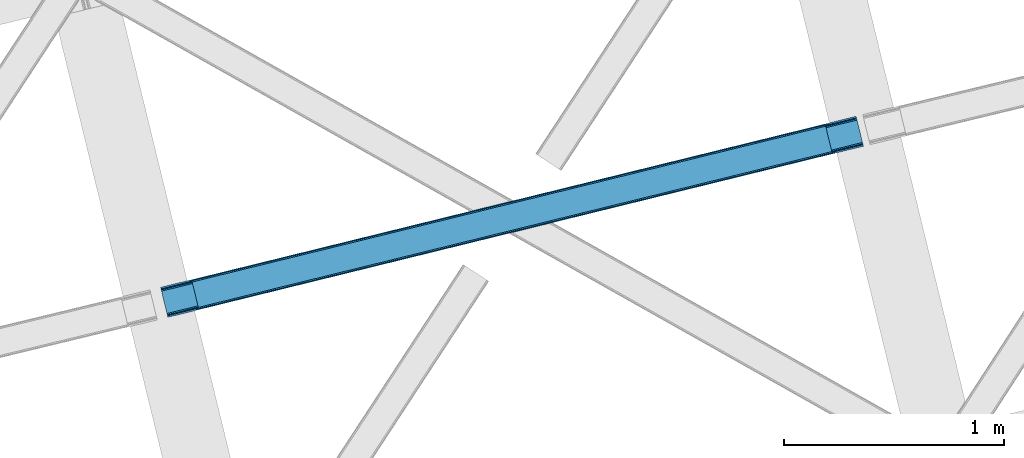
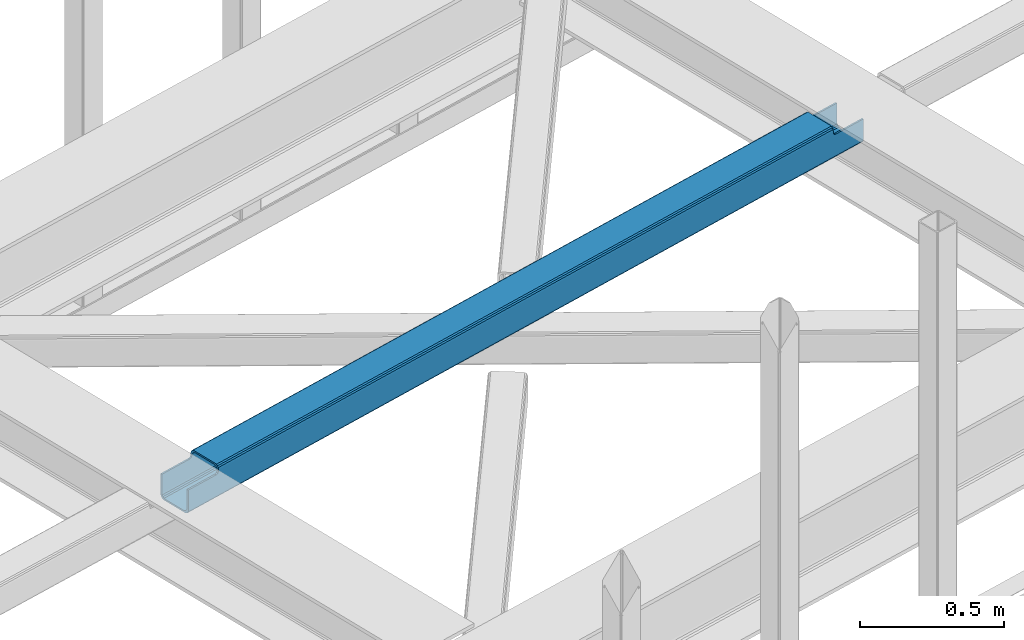
# One storey, part 34 of 66: 1 beam.
"""IFC4 building model written with IfcOpenShell, lengths in millimetres."""

from ifc_helpers import new_model, entity, si_unit, converted_unit, derived_unit, direction, frame, origin, place, context, subcontext, project, spatial, triangles, type_object, element, save


model = new_model("IFC4")

# Units and contexts
model_context = context("Model", 3, precision=0.01, world=origin(), true_north=direction((6.12303176911189e-17, 1.0)))
plan_context = context("Plan", 3, precision=0.01, world=origin(), true_north=direction((6.12303176911189e-17, 1.0)))
body_context = subcontext(model_context, "Body", "Model", "MODEL_VIEW")
ifc_project = project(units=[si_unit("LENGTHUNIT", "METRE", prefix="MILLI"), si_unit("AREAUNIT", "SQUARE_METRE"), si_unit("VOLUMEUNIT", "CUBIC_METRE"), converted_unit("PLANEANGLEUNIT", "DEGREE", entity("IfcRatioMeasure", 0.0174532925199433), si_unit("PLANEANGLEUNIT", "RADIAN"), dimensions=[0, 0, 0, 0, 0, 0, 0]), si_unit("MASSUNIT", "GRAM", prefix="KILO"), derived_unit("MASSDENSITYUNIT", [(si_unit("MASSUNIT", "GRAM", prefix="KILO"), 1), (si_unit("LENGTHUNIT", "METRE"), -3)]), derived_unit("MOMENTOFINERTIAUNIT", [(si_unit("LENGTHUNIT", "METRE"), 4)]), si_unit("TIMEUNIT", "SECOND"), si_unit("FREQUENCYUNIT", "HERTZ"), si_unit("THERMODYNAMICTEMPERATUREUNIT", "DEGREE_CELSIUS"), derived_unit("THERMALTRANSMITTANCEUNIT", [(si_unit("MASSUNIT", "GRAM", prefix="KILO"), 1), (si_unit("THERMODYNAMICTEMPERATUREUNIT", "KELVIN"), -1), (si_unit("TIMEUNIT", "SECOND"), -3)]), derived_unit("VOLUMETRICFLOWRATEUNIT", [(si_unit("LENGTHUNIT", "METRE"), 3), (si_unit("TIMEUNIT", "SECOND"), -1)]), derived_unit("MASSFLOWRATEUNIT", [(si_unit("MASSUNIT", "GRAM", prefix="KILO"), 1), (si_unit("TIMEUNIT", "SECOND"), -1)]), derived_unit("ROTATIONALFREQUENCYUNIT", [(si_unit("TIMEUNIT", "SECOND"), -1)]), si_unit("ELECTRICCURRENTUNIT", "AMPERE"), si_unit("ELECTRICVOLTAGEUNIT", "VOLT"), si_unit("POWERUNIT", "WATT"), si_unit("FORCEUNIT", "NEWTON", prefix="KILO"), si_unit("ILLUMINANCEUNIT", "LUX"), si_unit("LUMINOUSFLUXUNIT", "LUMEN"), si_unit("LUMINOUSINTENSITYUNIT", "CANDELA"), derived_unit("USERDEFINED", [(si_unit("MASSUNIT", "GRAM", prefix="KILO"), -1), (si_unit("LENGTHUNIT", "METRE"), -2), (si_unit("TIMEUNIT", "SECOND"), 3), (si_unit("LUMINOUSFLUXUNIT", "LUMEN"), 1)]), derived_unit("LINEARVELOCITYUNIT", [(si_unit("LENGTHUNIT", "METRE"), 1), (si_unit("TIMEUNIT", "SECOND"), -1)]), si_unit("PRESSUREUNIT", "PASCAL"), derived_unit("USERDEFINED", [(si_unit("LENGTHUNIT", "METRE"), -2), (si_unit("MASSUNIT", "GRAM", prefix="KILO"), 1), (si_unit("TIMEUNIT", "SECOND"), -2)]), derived_unit("LINEARFORCEUNIT", [(si_unit("MASSUNIT", "GRAM", prefix="KILO"), 1), (si_unit("LENGTHUNIT", "METRE"), 1), (si_unit("TIMEUNIT", "SECOND"), -2), (si_unit("LENGTHUNIT", "METRE"), -1)]), derived_unit("PLANARFORCEUNIT", [(si_unit("MASSUNIT", "GRAM", prefix="KILO"), 1), (si_unit("LENGTHUNIT", "METRE"), 1), (si_unit("TIMEUNIT", "SECOND"), -2), (si_unit("LENGTHUNIT", "METRE"), -2)])], contexts=[model_context, plan_context])

# Site, building, storey
site_placement = place(None, origin())
site = spatial("IfcSite", under=ifc_project, at=site_placement, CompositionType="ELEMENT")
building_placement = place(site_placement, origin())
building = spatial("IfcBuilding", under=site, at=building_placement, CompositionType="ELEMENT")
storey_placement = place(building_placement, frame((0.0, 0.0, 19800.0)))
storey = spatial("IfcBuildingStorey", under=building, at=storey_placement, Name="06", CompositionType="ELEMENT", Elevation=19800.0)

# Beam
beam_type = type_object("IfcBeamType", PredefinedType="BEAM")
beam_placement = place(storey_placement, frame((-36151.91, 10320.64, 3967.03)))
element("IfcBeam", 1, at=beam_placement, inside=storey, type_object=beam_type, ObjectType="Steel Beam", PredefinedType="BEAM", context=body_context, shape_type="Tessellation", body=[
    triangles([(3160.10943603516, 895.15698852539, 0.0), (3184.97536010742, 793.143447875977, 0.0), (4.14393310546438, 119.014828491212, 0.965057373046875), (29.012182617189, 17.0012878417965, 0.965057373046875), (3155.96550292968, 912.159439086914, 17.4989318847656), (3156.27943725586, 910.86533203125, 10.8016662597656), (0.0, 136.017279052734, 18.4639892578125), (0.316259765626455, 134.723171997071, 11.7667236328125), (3157.17938232422, 907.179510498047, 5.12526855468604), (1.21387939452688, 131.037350463868, 6.09032592773292), (3158.52348632812, 901.663568115235, 1.33247680664135), (2.5579833984375, 125.521408081055, 2.29753417968823), (3186.56130981445, 786.636868286134, 1.33247680664135), (30.5981323242158, 10.4947082519539, 2.29753417968823), (3187.90773925781, 781.12092590332, 5.12526855468604), (31.9422363281265, 4.97876586914026, 6.09032592773292), (3188.80535888672, 777.436267089844, 10.8016662597656), (32.8398559570269, 1.29410705566443, 11.7667236328125), (3189.12161865235, 776.140997314453, 17.4989318847656), (33.1561157226533, 0.0, 18.4639892578125), (2.87191772460938, 124.236602783203, 13.0898986816392), (4.21602172851271, 118.720660400391, 9.29710693359448), (5.80197143554688, 112.214080810547, 7.96463012695313), (1.97429809570167, 127.922424316406, 18.7662963867188), (0.0, 136.017279052734, 105.472631835935), (1.65803833007521, 129.216531372071, 25.4635620117188), (1.65803833007521, 129.216531372071, 105.472631835935), (28.9400939941406, 17.2966186523445, 9.29710693359448), (30.284197998044, 11.7806762695309, 13.0898986816392), (27.3541442871065, 23.8020355224617, 7.96463012695313), (31.1818176269517, 8.09485473632776, 18.7662963867188), (31.4980773925781, 6.80074768066515, 25.4635620117188), (33.1561157226533, 0.0, 105.472631835935), (31.4980773925781, 6.80074768066515, 105.472631835935), (3183.3196472168, 799.944195556642, 6.99957275390625), (3161.76747436523, 888.356240844727, 6.99957275390625), (3160.1815246582, 894.862820434571, 8.3320495605476), (3158.83742065429, 900.378762817383, 12.1248413085923), (3157.93747558594, 904.064584350586, 17.8035644531228), (3157.62354125977, 905.358691406251, 24.4985046386719), (3187.46358032226, 782.942907714843, 24.4985046386719), (3187.14732055664, 784.237014770508, 17.8035644531228), (3186.24970092774, 787.922836303711, 12.1248413085923), (3184.90559692383, 793.438778686525, 8.3320495605476), (131.782653808594, 161.216903686523, 105.472631835935), (130.124615478511, 168.018814086914, 105.472631835935), (163.280731201172, 32.0003723144528, 105.472631835935), (161.622692871089, 38.8011199951179, 105.472631835935), (3155.96550292968, 912.159439086914, 104.491296386717), (3157.62354125977, 905.358691406251, 104.491296386717), (3189.12161865235, 776.140997314453, 104.491296386717), (3187.46358032226, 782.942907714843, 104.491296386717), (3025.84321289062, 880.157904052734, 104.491296386717), (3027.5012512207, 873.357156372071, 104.491296386717), (3057.3412902832, 750.941372680665, 104.491296386717), (3058.99932861328, 744.140625, 104.491296386717), (3022.06437377929, 879.228890991211, 106.102825927734), (3023.72241210938, 872.428143310548, 106.102825927734), (3018.29018554687, 878.301040649414, 107.71435546875), (3019.94822387695, 871.500292968751, 107.71435546875), (3016.72516479492, 877.916180419923, 111.602490234374), (3018.383203125, 871.115432739258, 111.602490234374), (3015.16246948242, 877.53132019043, 115.492950439453), (3016.8205078125, 870.730572509767, 115.541784667967), (3049.88128051758, 741.898901367187, 111.602490234374), (3048.2232421875, 748.699649047852, 111.602490234374), (3046.660546875, 748.314788818359, 115.492950439453), (3048.31858520507, 741.514041137696, 115.492950439453), (3051.44630126953, 742.28376159668, 107.71435546875), (3049.78826293945, 749.084509277343, 107.71435546875), (3055.22048950195, 743.211611938477, 106.102825927734), (3053.56245117187, 750.012359619141, 106.102825927734), (140.910003662109, 163.462115478516, 112.581500244141), (142.463397216794, 163.844650268555, 116.471960449217), (139.335681152341, 163.074929809571, 108.693365478513), (135.556842041013, 162.145916748048, 107.081835937501), (170.750042724605, 41.046331787109, 112.581500244141), (169.175720214844, 40.6591461181652, 108.693365478513), (165.39920654297, 39.7301330566406, 107.081835937501), (172.303436279297, 41.4288665771492, 116.471960449217), (139.240338134761, 170.260537719727, 112.583825683592), (140.805358886719, 170.64539794922, 116.471960449217), (137.677642822266, 169.875677490234, 108.693365478513), (133.901129150392, 168.946664428711, 107.081835937501), (170.833758544919, 33.8583984375, 108.693365478513), (172.396453857422, 34.2420959472656, 112.583825683592), (173.961474609372, 34.6269561767585, 116.471960449217), (167.054919433591, 32.9293853759773, 107.081835937501), (3015.16246948242, 877.53132019043, 122.541357421873), (140.805358886719, 170.64539794922, 123.420373535155), (3048.31858520507, 741.514041137696, 122.541357421873), (173.961474609372, 34.6269561767585, 123.420373535155), (3017.13444213867, 869.436465454102, 122.239050292967), (142.77965698242, 162.55054321289, 123.118066406249), (3018.03438720703, 865.750643920899, 127.917773437501), (143.677276611328, 158.864721679687, 128.794464111328), (3019.37849121093, 860.234701538086, 131.710565185545), (145.021380615231, 153.348779296875, 132.589581298827), (3020.96444091797, 853.728121948243, 133.043041992187), (146.607330322266, 146.842199707031, 133.922058105469), (3046.34428710937, 749.608895874024, 122.239050292967), (171.98717651367, 42.7229736328136, 123.118066406249), (3042.51661376953, 765.317239379883, 133.043041992187), (3044.10256347656, 758.810659790039, 131.710565185545), (168.159503173825, 58.4301544189457, 133.922058105469), (169.745452880859, 51.9247375488285, 132.589581298827), (3045.44666748046, 753.294717407227, 127.917773437501), (171.089556884763, 46.4087951660167, 128.796789550779), (3015.47640380859, 876.237213134766, 129.238623046873), (3016.37634887695, 872.551391601563, 134.917346191407), (3017.72045288086, 867.035449218751, 138.710137939452), (3019.30640258789, 860.530032348634, 140.042614746093), (3045.75827636719, 752.009912109375, 138.710137939452), (3044.17232666015, 758.51649169922, 140.042614746093), (3047.10470581055, 746.493969726564, 134.917346191407), (3048.00232543945, 742.80814819336, 129.238623046873), (141.121618652345, 169.351290893555, 130.117639160155), (142.019238281246, 165.665469360352, 135.796362304685), (143.363342285156, 160.149526977539, 139.589154052734), (144.949291992183, 153.642947387696, 140.921630859375), (171.403491210935, 45.1228271484379, 139.589154052734), (169.817541503908, 51.6294067382823, 140.921630859375), (172.747595214845, 39.6068847656261, 135.796362304685), (173.645214843746, 35.9222259521484, 130.117639160155)], [[1, 2, 3], [4, 3, 2], [5, 6, 7], [8, 7, 6], [6, 9, 8], [10, 8, 9], [9, 11, 10], [12, 10, 11], [11, 1, 12], [3, 12, 1], [2, 13, 4], [14, 4, 13], [13, 15, 14], [16, 14, 15], [15, 17, 16], [18, 16, 17], [17, 19, 18], [20, 18, 19], [21, 8, 10], [21, 10, 12], [21, 12, 22], [23, 3, 4], [3, 22, 12], [23, 22, 3], [8, 24, 7], [25, 26, 27], [25, 7, 26], [8, 21, 24], [24, 26, 7], [28, 14, 29], [4, 30, 23], [28, 4, 14], [4, 28, 30], [16, 18, 29], [29, 14, 16], [18, 31, 29], [32, 31, 20], [20, 31, 18], [32, 33, 34], [20, 33, 32], [35, 36, 23], [23, 30, 35], [36, 37, 22], [22, 23, 36], [37, 38, 21], [21, 22, 37], [38, 39, 24], [24, 21, 38], [39, 40, 26], [26, 24, 39], [41, 42, 31], [31, 32, 41], [42, 43, 29], [29, 31, 42], [43, 44, 28], [28, 29, 43], [44, 35, 30], [30, 28, 44], [45, 46, 25], [25, 27, 45], [47, 48, 34], [34, 33, 47], [6, 5, 39], [49, 40, 5], [40, 49, 50], [40, 39, 5], [38, 6, 39], [38, 9, 6], [11, 38, 37], [38, 11, 9], [37, 1, 11], [1, 36, 2], [36, 1, 37], [17, 43, 42], [42, 19, 17], [42, 41, 19], [41, 51, 19], [52, 51, 41], [44, 43, 13], [2, 44, 13], [35, 2, 36], [2, 35, 44], [13, 43, 15], [15, 43, 17], [50, 49, 53], [53, 54, 50], [51, 52, 55], [55, 56, 51], [54, 53, 57], [57, 58, 54], [58, 57, 59], [59, 60, 58], [60, 59, 61], [61, 62, 60], [62, 61, 63], [63, 64, 62], [65, 66, 67], [67, 68, 65], [69, 70, 66], [66, 65, 69], [71, 72, 70], [70, 69, 71], [56, 55, 72], [72, 71, 56], [40, 60, 26], [62, 73, 60], [58, 60, 40], [62, 64, 74], [40, 54, 58], [54, 40, 50], [26, 60, 75], [75, 60, 73], [74, 73, 62], [75, 76, 26], [45, 26, 76], [26, 45, 27], [70, 41, 32], [72, 41, 70], [52, 41, 55], [72, 55, 41], [67, 66, 77], [66, 70, 77], [78, 70, 32], [32, 79, 78], [48, 79, 32], [32, 34, 48], [78, 77, 70], [77, 80, 67], [81, 73, 74], [74, 82, 81], [73, 81, 83], [76, 84, 46], [46, 45, 76], [75, 83, 84], [84, 76, 75], [83, 75, 73], [78, 85, 86], [86, 87, 80], [80, 77, 86], [86, 77, 78], [85, 78, 79], [79, 88, 85], [88, 79, 48], [48, 47, 88], [59, 5, 7], [57, 5, 59], [49, 5, 53], [57, 53, 5], [63, 61, 81], [61, 59, 83], [89, 63, 82], [83, 59, 7], [7, 84, 83], [46, 84, 7], [7, 25, 46], [81, 82, 63], [82, 90, 89], [83, 81, 61], [19, 69, 20], [68, 86, 65], [69, 65, 85], [68, 91, 87], [71, 69, 19], [19, 51, 56], [56, 71, 19], [20, 69, 85], [86, 68, 87], [92, 87, 91], [86, 85, 65], [20, 85, 88], [88, 47, 20], [33, 20, 47], [93, 94, 74], [74, 64, 93], [93, 95, 94], [96, 94, 95], [95, 97, 96], [98, 96, 97], [97, 99, 98], [100, 98, 99], [80, 101, 67], [80, 102, 101], [103, 104, 105], [106, 105, 104], [104, 107, 106], [108, 106, 107], [107, 101, 108], [102, 108, 101], [99, 103, 100], [105, 100, 103], [95, 109, 110], [95, 110, 111], [95, 111, 97], [99, 112, 103], [112, 97, 111], [99, 97, 112], [109, 93, 89], [64, 89, 93], [64, 63, 89], [109, 95, 93], [104, 113, 107], [114, 103, 112], [104, 114, 113], [114, 104, 103], [115, 116, 107], [107, 113, 115], [116, 101, 107], [67, 101, 91], [91, 101, 116], [91, 68, 67], [96, 117, 118], [96, 118, 119], [96, 119, 98], [100, 120, 105], [120, 98, 119], [100, 98, 120], [117, 94, 90], [74, 90, 94], [74, 82, 90], [117, 96, 94], [106, 121, 108], [122, 105, 120], [106, 122, 121], [122, 106, 105], [123, 124, 108], [108, 121, 123], [124, 102, 108], [80, 102, 92], [92, 102, 124], [92, 87, 80], [112, 111, 119], [119, 120, 112], [111, 110, 118], [118, 119, 111], [110, 109, 117], [117, 118, 110], [109, 89, 90], [90, 117, 109], [114, 112, 120], [120, 122, 114], [91, 116, 124], [124, 92, 91], [116, 115, 123], [123, 124, 116], [115, 113, 121], [121, 123, 115], [113, 114, 122], [122, 121, 113]]),
])

save(model, "model.ifc")
